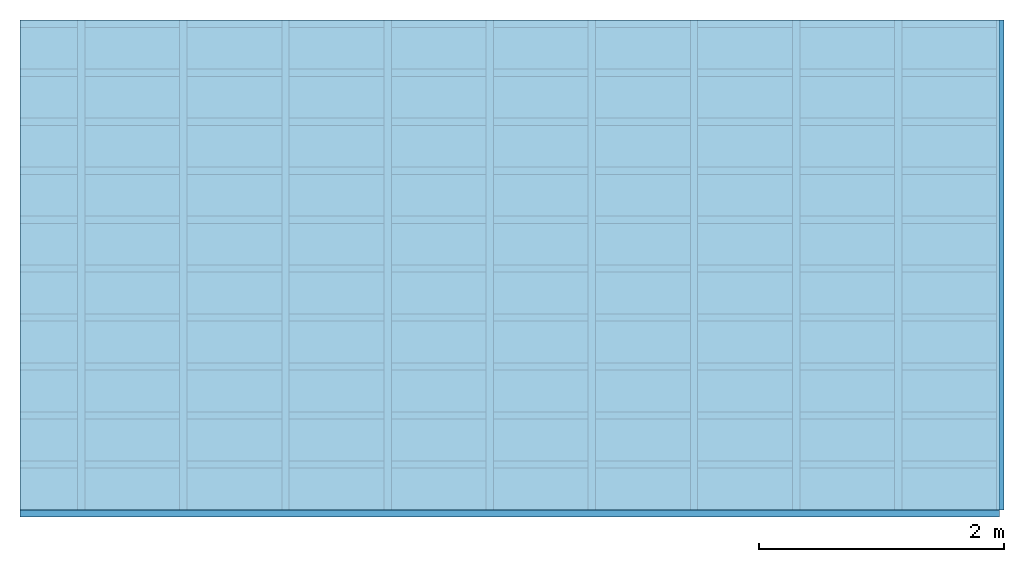
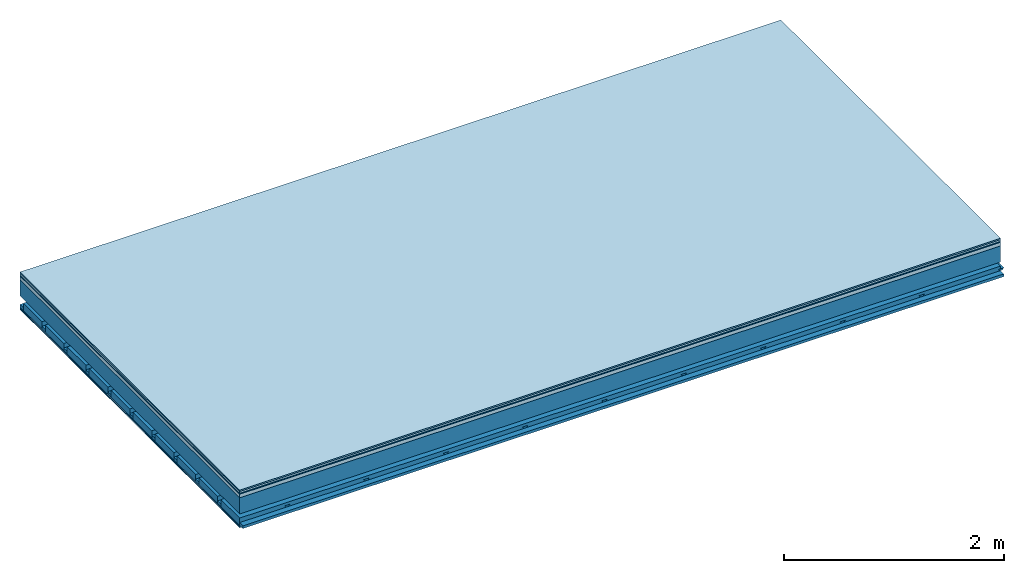
# One storey: 7 plates, 4 members, 1 element without a shape of its own.
"""IFC4 building model written with IfcOpenShell, lengths in metres."""

from ifc_helpers import new_model, si_unit, derived_unit, direction, frame, frame_2d, origin, origin_with_axes, place, context, project, spatial, polyline, rectangle, outline, extrude, material, layer, layer_set, type_object, element, aggregate, save


model = new_model("IFC4")

# Units and contexts
plan_context = context("Plan", 3, precision=1e-05, world=origin(), true_north=direction((0.0, 1.0)))
model_context = context("Model", 3, precision=1e-05, world=origin(), true_north=direction((0.0, 1.0)))
ifc_project = project(units=[si_unit("LENGTHUNIT", "METRE"), derived_unit("SOUNDPRESSUREUNIT", [(si_unit("PRESSUREUNIT", "PASCAL", prefix="MICRO"), 0)]), si_unit("ENERGYUNIT", "JOULE", prefix="MEGA"), si_unit("MASSUNIT", "GRAM", prefix="KILO"), derived_unit("THERMALTRANSMITTANCEUNIT", [(si_unit("POWERUNIT", "WATT"), 1), (si_unit("AREAUNIT", "SQUARE_METRE"), -1), (si_unit("THERMODYNAMICTEMPERATUREUNIT", "KELVIN"), -1)]), derived_unit("AREADENSITYUNIT", [(si_unit("MASSUNIT", "GRAM", prefix="KILO"), 1), (si_unit("AREAUNIT", "SQUARE_METRE"), -1)]), derived_unit("USERDEFINED", [(si_unit("ENERGYUNIT", "JOULE", prefix="MEGA"), 1), (si_unit("AREAUNIT", "SQUARE_METRE"), -1)])], contexts=[plan_context, model_context])

# Site, building, storey
site = spatial("IfcSite", under=ifc_project)
building_placement = place(None, origin())
building = spatial("IfcBuilding", under=site, at=building_placement)
storey_placement = place(building_placement, origin())
storey = spatial("IfcBuildingStorey", under=building, at=storey_placement)

# Slab, members, plates
ifc_material_1 = material(Category="11.013")
ifc_layer_1 = layer(ifc_material_1, 0.015, Name="Flooring")
ifc_material_2 = material(Category="03.007")
ifc_layer_2 = layer(ifc_material_2, 0.02, Name="On-material")
ifc_material_3 = material(Name="Wood fiber generic product", Category="10.009")
ifc_layer_3 = layer(ifc_material_3, 0.01, Name="Impact sound insulation")
ifc_material_4 = material(Name="Concrete panels", Category="02.007")
ifc_layer_4 = layer(ifc_material_4, 0.04, Name="on Supporting structure")
ifc_material_5 = material(Name="no composite action")
ifc_layer_5 = layer(ifc_material_5, 0.0, Name="Bond")
ifc_layer_6 = layer(None, 0.18, Name="Supporting structure")
ifc_layer_7 = layer(ifc_material_5, 0.0, Name="Bond")
ifc_layer_8 = layer(None, 0.095, Name="Coupling")
ifc_layer_9 = layer(None, 0.03, Name="Battens / profiles")
ifc_material_6 = material(Name="Plasterboard type A", Category="03.008")
ifc_layer_10 = layer(ifc_material_6, 0.0125, Name="Ceiling covering 1st layer")
ifc_layer_11 = layer(ifc_material_6, 0.0125, Name="Ceiling covering layer 2")
ifc_material_7 = material(Category="04.001")
ifc_layer_12 = layer(ifc_material_7, 0.003, Name="Surface / treatment")
ifc_layer_set = layer_set([ifc_layer_1, ifc_layer_2, ifc_layer_3, ifc_layer_4, ifc_layer_5, ifc_layer_6, ifc_layer_7, ifc_layer_8, ifc_layer_9, ifc_layer_10, ifc_layer_11, ifc_layer_12])
slab_type = type_object("IfcSlabType", Name="A2135", PredefinedType="NOTDEFINED", material=ifc_layer_set)
slab_placement = place(None, frame((0.0, 0.0, 0.0), z_axis=(0.0, 0.0, -1.0), x_axis=(1.0, 0.0, 0.0)))
slab = element("IfcSlab", 1, at=slab_placement, inside=storey, type_object=slab_type, material=ifc_layer_set, Name="Slab #1")
ifc_material_8 = material(Name="Solid timber panel")
member_1_placement = place(slab_placement, origin())
member_1 = element("IfcMember", 2, at=member_1_placement, material=ifc_material_8, Name="Supporting structure", context=plan_context, shape_type="SweptSolid", body=[
    extrude(rectangle(XDim=1.0, YDim=0.18, at=frame_2d((0.5, 0.09), x_axis=(1.0, 0.0))), frame((0.0, 4.0, 0.085), z_axis=(0.0, -1.0, 0.0), x_axis=(1.0, 0.0, 0.0)), (0.0, 0.0, 1.0), 4.0),
    extrude(rectangle(XDim=1.0, YDim=0.18, at=frame_2d((0.5, 0.09), x_axis=(1.0, 0.0))), frame((1.0, 4.0, 0.085), z_axis=(0.0, -1.0, 0.0), x_axis=(1.0, 0.0, 0.0)), (0.0, 0.0, 1.0), 4.0),
    extrude(rectangle(XDim=1.0, YDim=0.18, at=frame_2d((0.5, 0.09), x_axis=(1.0, 0.0))), frame((2.0, 4.0, 0.085), z_axis=(0.0, -1.0, 0.0), x_axis=(1.0, 0.0, 0.0)), (0.0, 0.0, 1.0), 4.0),
    extrude(rectangle(XDim=1.0, YDim=0.18, at=frame_2d((0.5, 0.09), x_axis=(1.0, 0.0))), frame((3.0, 4.0, 0.085), z_axis=(0.0, -1.0, 0.0), x_axis=(1.0, 0.0, 0.0)), (0.0, 0.0, 1.0), 4.0),
    extrude(rectangle(XDim=1.0, YDim=0.18, at=frame_2d((0.5, 0.09), x_axis=(1.0, 0.0))), frame((4.0, 4.0, 0.085), z_axis=(0.0, -1.0, 0.0), x_axis=(1.0, 0.0, 0.0)), (0.0, 0.0, 1.0), 4.0),
    extrude(rectangle(XDim=1.0, YDim=0.18, at=frame_2d((0.5, 0.09), x_axis=(1.0, 0.0))), frame((5.0, 4.0, 0.085), z_axis=(0.0, -1.0, 0.0), x_axis=(1.0, 0.0, 0.0)), (0.0, 0.0, 1.0), 4.0),
    extrude(rectangle(XDim=1.0, YDim=0.18, at=frame_2d((0.5, 0.09), x_axis=(1.0, 0.0))), frame((6.0, 4.0, 0.085), z_axis=(0.0, -1.0, 0.0), x_axis=(1.0, 0.0, 0.0)), (0.0, 0.0, 1.0), 4.0),
    extrude(rectangle(XDim=1.0, YDim=0.18, at=frame_2d((0.5, 0.09), x_axis=(1.0, 0.0))), frame((7.0, 4.0, 0.085), z_axis=(0.0, -1.0, 0.0), x_axis=(1.0, 0.0, 0.0)), (0.0, 0.0, 1.0), 4.0),
])
ifc_material_9 = material()
member_2_placement = place(slab_placement, origin())
member_2 = element("IfcMember", 3, at=member_2_placement, material=ifc_material_9, Name="Coupling", context=plan_context, shape_type="SweptSolid", body=[
    extrude(outline(polyline([(0.0, 0.0), (0.06, 0.0), (0.04, 0.02), (0.02, 0.02), (0.0, 0.0)])), frame((0.47, 4.0, 0.34), z_axis=(0.0, -1.0, 0.0), x_axis=(1.0, 0.0, 0.0)), (0.0, 0.0, 1.0), 4.0),
    extrude(outline(polyline([(0.0, 0.0), (0.06, 0.0), (0.04, 0.02), (0.02, 0.02), (0.0, 0.0)])), frame((1.304, 4.0, 0.34), z_axis=(0.0, -1.0, 0.0), x_axis=(1.0, 0.0, 0.0)), (0.0, 0.0, 1.0), 4.0),
    extrude(outline(polyline([(0.0, 0.0), (0.06, 0.0), (0.04, 0.02), (0.02, 0.02), (0.0, 0.0)])), frame((2.138, 4.0, 0.34), z_axis=(0.0, -1.0, 0.0), x_axis=(1.0, 0.0, 0.0)), (0.0, 0.0, 1.0), 4.0),
    extrude(outline(polyline([(0.0, 0.0), (0.06, 0.0), (0.04, 0.02), (0.02, 0.02), (0.0, 0.0)])), frame((2.972, 4.0, 0.34), z_axis=(0.0, -1.0, 0.0), x_axis=(1.0, 0.0, 0.0)), (0.0, 0.0, 1.0), 4.0),
    extrude(outline(polyline([(0.0, 0.0), (0.06, 0.0), (0.04, 0.02), (0.02, 0.02), (0.0, 0.0)])), frame((3.806, 4.0, 0.34), z_axis=(0.0, -1.0, 0.0), x_axis=(1.0, 0.0, 0.0)), (0.0, 0.0, 1.0), 4.0),
    extrude(outline(polyline([(0.0, 0.0), (0.06, 0.0), (0.04, 0.02), (0.02, 0.02), (0.0, 0.0)])), frame((4.64, 4.0, 0.34), z_axis=(0.0, -1.0, 0.0), x_axis=(1.0, 0.0, 0.0)), (0.0, 0.0, 1.0), 4.0),
    extrude(outline(polyline([(0.0, 0.0), (0.06, 0.0), (0.04, 0.02), (0.02, 0.02), (0.0, 0.0)])), frame((5.474, 4.0, 0.34), z_axis=(0.0, -1.0, 0.0), x_axis=(1.0, 0.0, 0.0)), (0.0, 0.0, 1.0), 4.0),
    extrude(outline(polyline([(0.0, 0.0), (0.06, 0.0), (0.04, 0.02), (0.02, 0.02), (0.0, 0.0)])), frame((6.308, 4.0, 0.34), z_axis=(0.0, -1.0, 0.0), x_axis=(1.0, 0.0, 0.0)), (0.0, 0.0, 1.0), 4.0),
    extrude(outline(polyline([(0.0, 0.0), (0.06, 0.0), (0.04, 0.02), (0.02, 0.02), (0.0, 0.0)])), frame((7.142, 4.0, 0.34), z_axis=(0.0, -1.0, 0.0), x_axis=(1.0, 0.0, 0.0)), (0.0, 0.0, 1.0), 4.0),
    extrude(outline(polyline([(0.0, 0.0), (0.06, 0.0), (0.04, 0.02), (0.02, 0.02), (0.0, 0.0)])), frame((7.976, 4.0, 0.34), z_axis=(0.0, -1.0, 0.0), x_axis=(1.0, 0.0, 0.0)), (0.0, 0.0, 1.0), 4.0),
])
member_3_placement = place(slab_placement, origin())
member_3 = element("IfcMember", 4, at=member_3_placement, material=ifc_material_9, Name="Battens / profiles", context=plan_context, shape_type="SweptSolid", body=[
    extrude(rectangle(XDim=0.06, YDim=0.03, at=frame_2d((0.03, 0.015), x_axis=(1.0, 0.0))), frame((0.0, 0.0, 0.36), z_axis=(1.0, 0.0, 0.0), x_axis=(0.0, 1.0, 0.0)), (0.0, 0.0, 1.0), 8.0),
    extrude(rectangle(XDim=0.06, YDim=0.03, at=frame_2d((0.03, 0.015), x_axis=(1.0, 0.0))), frame((0.0, 0.4, 0.36), z_axis=(1.0, 0.0, 0.0), x_axis=(0.0, 1.0, 0.0)), (0.0, 0.0, 1.0), 8.0),
    extrude(rectangle(XDim=0.06, YDim=0.03, at=frame_2d((0.03, 0.015), x_axis=(1.0, 0.0))), frame((0.0, 0.8, 0.36), z_axis=(1.0, 0.0, 0.0), x_axis=(0.0, 1.0, 0.0)), (0.0, 0.0, 1.0), 8.0),
    extrude(rectangle(XDim=0.06, YDim=0.03, at=frame_2d((0.03, 0.015), x_axis=(1.0, 0.0))), frame((0.0, 1.2, 0.36), z_axis=(1.0, 0.0, 0.0), x_axis=(0.0, 1.0, 0.0)), (0.0, 0.0, 1.0), 8.0),
    extrude(rectangle(XDim=0.06, YDim=0.03, at=frame_2d((0.03, 0.015), x_axis=(1.0, 0.0))), frame((0.0, 1.6, 0.36), z_axis=(1.0, 0.0, 0.0), x_axis=(0.0, 1.0, 0.0)), (0.0, 0.0, 1.0), 8.0),
    extrude(rectangle(XDim=0.06, YDim=0.03, at=frame_2d((0.03, 0.015), x_axis=(1.0, 0.0))), frame((0.0, 2.0, 0.36), z_axis=(1.0, 0.0, 0.0), x_axis=(0.0, 1.0, 0.0)), (0.0, 0.0, 1.0), 8.0),
    extrude(rectangle(XDim=0.06, YDim=0.03, at=frame_2d((0.03, 0.015), x_axis=(1.0, 0.0))), frame((0.0, 2.4, 0.36), z_axis=(1.0, 0.0, 0.0), x_axis=(0.0, 1.0, 0.0)), (0.0, 0.0, 1.0), 8.0),
    extrude(rectangle(XDim=0.06, YDim=0.03, at=frame_2d((0.03, 0.015), x_axis=(1.0, 0.0))), frame((0.0, 2.8, 0.36), z_axis=(1.0, 0.0, 0.0), x_axis=(0.0, 1.0, 0.0)), (0.0, 0.0, 1.0), 8.0),
    extrude(rectangle(XDim=0.06, YDim=0.03, at=frame_2d((0.03, 0.015), x_axis=(1.0, 0.0))), frame((0.0, 3.2, 0.36), z_axis=(1.0, 0.0, 0.0), x_axis=(0.0, 1.0, 0.0)), (0.0, 0.0, 1.0), 8.0),
    extrude(rectangle(XDim=0.06, YDim=0.03, at=frame_2d((0.03, 0.015), x_axis=(1.0, 0.0))), frame((0.0, 3.6, 0.36), z_axis=(1.0, 0.0, 0.0), x_axis=(0.0, 1.0, 0.0)), (0.0, 0.0, 1.0), 8.0),
    extrude(rectangle(XDim=0.06, YDim=0.03, at=frame_2d((0.03, 0.015), x_axis=(1.0, 0.0))), frame((0.0, 4.0, 0.36), z_axis=(1.0, 0.0, 0.0), x_axis=(0.0, 1.0, 0.0)), (0.0, 0.0, 1.0), 8.0),
])
ifc_material_10 = material()
member_4_placement = place(slab_placement, origin())
member_4 = element("IfcMember", 5, at=member_4_placement, material=ifc_material_10, Name="Cavity", context=plan_context, shape_type="SweptSolid", body=[
    extrude(rectangle(XDim=0.34, YDim=0.08, at=frame_2d((0.17, 0.04), x_axis=(1.0, 0.0))), frame((0.0, 0.06, 0.31), z_axis=(1.0, 0.0, 0.0), x_axis=(0.0, 1.0, 0.0)), (0.0, 0.0, 1.0), 8.0),
    extrude(rectangle(XDim=0.34, YDim=0.08, at=frame_2d((0.17, 0.04), x_axis=(1.0, 0.0))), frame((0.0, 0.46, 0.31), z_axis=(1.0, 0.0, 0.0), x_axis=(0.0, 1.0, 0.0)), (0.0, 0.0, 1.0), 8.0),
    extrude(rectangle(XDim=0.34, YDim=0.08, at=frame_2d((0.17, 0.04), x_axis=(1.0, 0.0))), frame((0.0, 0.86, 0.31), z_axis=(1.0, 0.0, 0.0), x_axis=(0.0, 1.0, 0.0)), (0.0, 0.0, 1.0), 8.0),
    extrude(rectangle(XDim=0.34, YDim=0.08, at=frame_2d((0.17, 0.04), x_axis=(1.0, 0.0))), frame((0.0, 1.26, 0.31), z_axis=(1.0, 0.0, 0.0), x_axis=(0.0, 1.0, 0.0)), (0.0, 0.0, 1.0), 8.0),
    extrude(rectangle(XDim=0.34, YDim=0.08, at=frame_2d((0.17, 0.04), x_axis=(1.0, 0.0))), frame((0.0, 1.66, 0.31), z_axis=(1.0, 0.0, 0.0), x_axis=(0.0, 1.0, 0.0)), (0.0, 0.0, 1.0), 8.0),
    extrude(rectangle(XDim=0.34, YDim=0.08, at=frame_2d((0.17, 0.04), x_axis=(1.0, 0.0))), frame((0.0, 2.06, 0.31), z_axis=(1.0, 0.0, 0.0), x_axis=(0.0, 1.0, 0.0)), (0.0, 0.0, 1.0), 8.0),
    extrude(rectangle(XDim=0.34, YDim=0.08, at=frame_2d((0.17, 0.04), x_axis=(1.0, 0.0))), frame((0.0, 2.46, 0.31), z_axis=(1.0, 0.0, 0.0), x_axis=(0.0, 1.0, 0.0)), (0.0, 0.0, 1.0), 8.0),
    extrude(rectangle(XDim=0.34, YDim=0.08, at=frame_2d((0.17, 0.04), x_axis=(1.0, 0.0))), frame((0.0, 2.86, 0.31), z_axis=(1.0, 0.0, 0.0), x_axis=(0.0, 1.0, 0.0)), (0.0, 0.0, 1.0), 8.0),
    extrude(rectangle(XDim=0.34, YDim=0.08, at=frame_2d((0.17, 0.04), x_axis=(1.0, 0.0))), frame((0.0, 3.26, 0.31), z_axis=(1.0, 0.0, 0.0), x_axis=(0.0, 1.0, 0.0)), (0.0, 0.0, 1.0), 8.0),
    extrude(rectangle(XDim=0.34, YDim=0.08, at=frame_2d((0.17, 0.04), x_axis=(1.0, 0.0))), frame((0.0, 3.66, 0.31), z_axis=(1.0, 0.0, 0.0), x_axis=(0.0, 1.0, 0.0)), (0.0, 0.0, 1.0), 8.0),
])
plate_1_placement = place(slab_placement, origin())
plate_1 = element("IfcPlate", 6, at=plate_1_placement, material=ifc_material_1, Name="Flooring", context=plan_context, shape_type="SweptSolid", body=[
    extrude(rectangle(XDim=8.0, YDim=4.0, at=frame_2d((4.0, 2.0), x_axis=(1.0, 0.0))), origin_with_axes(), (0.0, 0.0, 1.0), 0.015),
])
plate_2_placement = place(slab_placement, origin())
plate_2 = element("IfcPlate", 7, at=plate_2_placement, material=ifc_material_2, Name="On-material", context=plan_context, shape_type="SweptSolid", body=[
    extrude(rectangle(XDim=8.0, YDim=4.0, at=frame_2d((4.0, 2.0), x_axis=(1.0, 0.0))), frame((0.0, 0.0, 0.015), z_axis=(0.0, 0.0, 1.0), x_axis=(1.0, 0.0, 0.0)), (0.0, 0.0, 1.0), 0.02),
])
plate_3_placement = place(slab_placement, origin())
plate_3 = element("IfcPlate", 8, at=plate_3_placement, material=ifc_material_3, Name="Impact sound insulation", context=plan_context, shape_type="SweptSolid", body=[
    extrude(rectangle(XDim=8.0, YDim=4.0, at=frame_2d((4.0, 2.0), x_axis=(1.0, 0.0))), frame((0.0, 0.0, 0.035), z_axis=(0.0, 0.0, 1.0), x_axis=(1.0, 0.0, 0.0)), (0.0, 0.0, 1.0), 0.01),
])
plate_4_placement = place(slab_placement, origin())
plate_4 = element("IfcPlate", 9, at=plate_4_placement, material=ifc_material_4, Name="on Supporting structure", context=plan_context, shape_type="SweptSolid", body=[
    extrude(rectangle(XDim=8.0, YDim=4.0, at=frame_2d((4.0, 2.0), x_axis=(1.0, 0.0))), frame((0.0, 0.0, 0.045), z_axis=(0.0, 0.0, 1.0), x_axis=(1.0, 0.0, 0.0)), (0.0, 0.0, 1.0), 0.04),
])
plate_5_placement = place(slab_placement, origin())
plate_5 = element("IfcPlate", 10, at=plate_5_placement, material=ifc_material_6, Name="Ceiling covering 1st layer", context=plan_context, shape_type="SweptSolid", body=[
    extrude(rectangle(XDim=8.0, YDim=4.0, at=frame_2d((4.0, 2.0), x_axis=(1.0, 0.0))), frame((0.0, 0.0, 0.39), z_axis=(0.0, 0.0, 1.0), x_axis=(1.0, 0.0, 0.0)), (0.0, 0.0, 1.0), 0.0125),
])
plate_6_placement = place(slab_placement, origin())
plate_6 = element("IfcPlate", 11, at=plate_6_placement, material=ifc_material_6, Name="Ceiling covering layer 2", context=plan_context, shape_type="SweptSolid", body=[
    extrude(rectangle(XDim=8.0, YDim=4.0, at=frame_2d((4.0, 2.0), x_axis=(1.0, 0.0))), frame((0.0, 0.0, 0.4025), z_axis=(0.0, 0.0, 1.0), x_axis=(1.0, 0.0, 0.0)), (0.0, 0.0, 1.0), 0.0125),
])
plate_7_placement = place(slab_placement, origin())
plate_7 = element("IfcPlate", 12, at=plate_7_placement, material=ifc_material_7, Name="Surface / treatment", context=plan_context, shape_type="SweptSolid", body=[
    extrude(rectangle(XDim=8.0, YDim=4.0, at=frame_2d((4.0, 2.0), x_axis=(1.0, 0.0))), frame((0.0, 0.0, 0.415), z_axis=(0.0, 0.0, 1.0), x_axis=(1.0, 0.0, 0.0)), (0.0, 0.0, 1.0), 0.003),
])
aggregate(slab, [plate_1, plate_2, plate_3, plate_4, member_1, member_2, member_3, member_4, plate_5, plate_6, plate_7])

save(model, "model.ifc")
